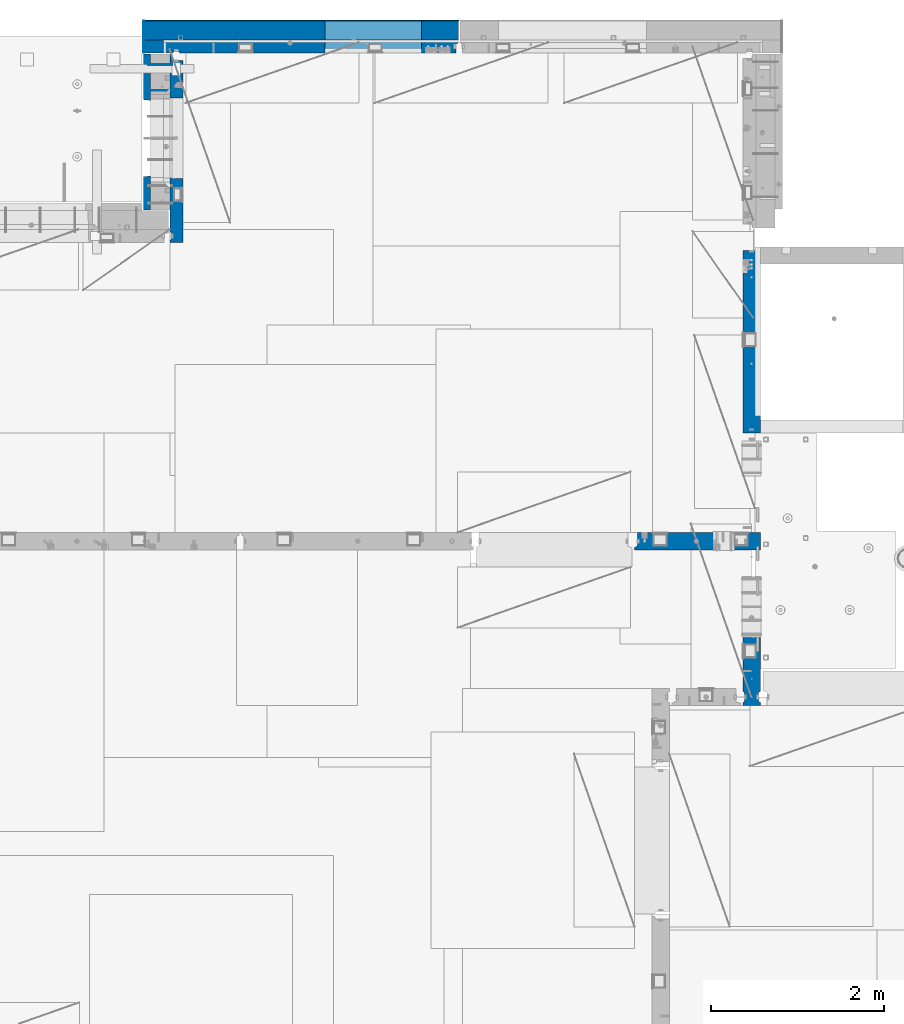
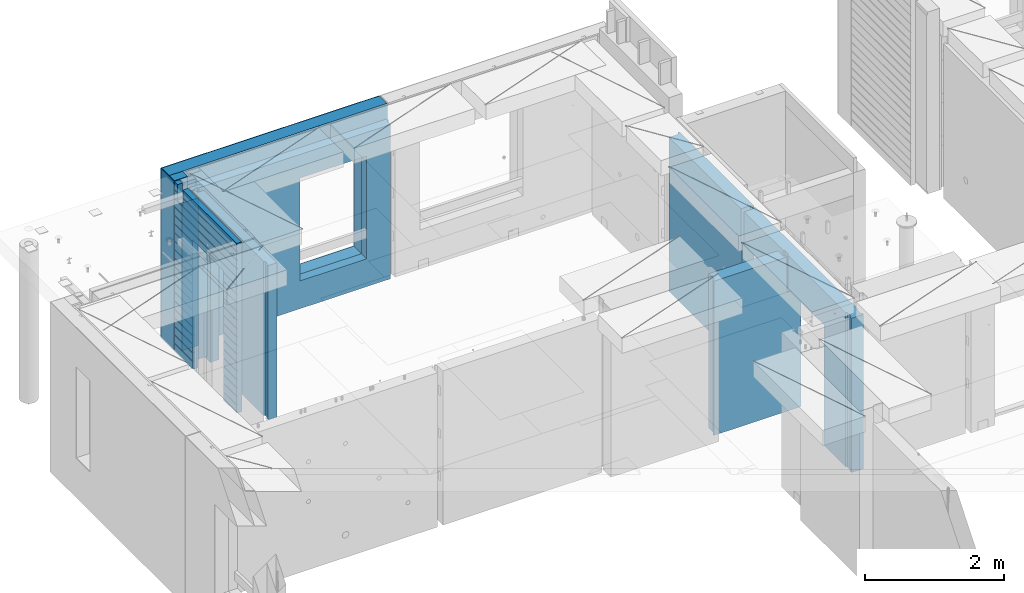
# One storey, part 202 of 309: 12 walls, 5 elements without a shape of their own.
"""IFC2X3 building model written with IfcOpenShell, lengths in millimetres."""

from ifc_helpers import new_model, si_unit, frame, origin_with_axes, place, context, subcontext, project, spatial, faceted_brep, material, type_object, element, aggregate, save


model = new_model("IFC2X3")

# Units and contexts
model_context = context("Model", 3, precision=1e-05, world=origin_with_axes())
body_context = subcontext(model_context, "Body", "Model", "MODEL_VIEW")
ifc_project = project(units=[si_unit("LENGTHUNIT", "METRE", prefix="MILLI"), si_unit("AREAUNIT", "SQUARE_METRE"), si_unit("VOLUMEUNIT", "CUBIC_METRE"), si_unit("MASSUNIT", "GRAM", prefix="KILO"), si_unit("TIMEUNIT", "SECOND"), si_unit("PLANEANGLEUNIT", "RADIAN"), si_unit("SOLIDANGLEUNIT", "STERADIAN"), si_unit("THERMODYNAMICTEMPERATUREUNIT", "DEGREE_CELSIUS"), si_unit("LUMINOUSINTENSITYUNIT", "LUMEN")], contexts=[model_context])

# Site, building, storey
site_placement = place(None, origin_with_axes())
site = spatial("IfcSite", under=ifc_project, at=site_placement, CompositionType="ELEMENT")
building_placement = place(site_placement, origin_with_axes())
building = spatial("IfcBuilding", under=site, at=building_placement, CompositionType="ELEMENT")
storey_placement = place(building_placement, origin_with_axes())
storey = spatial("IfcBuildingStorey", under=building, at=storey_placement, Name="7", CompositionType="ELEMENT", Elevation=0.0)

# Assembly, walls
assembly_1_placement = place(storey_placement, origin_with_axes())
assembly_1 = element("IfcElementAssembly", 1, at=assembly_1_placement, inside=storey, AssemblyPlace="NOTDEFINED", PredefinedType="REINFORCEMENT_UNIT")
ifc_material_1 = material(Name="Undefined")
wall_type_1 = type_object("IfcWallType", PredefinedType="NOTDEFINED")
wall_1_placement = place(assembly_1_placement, frame((11020.0, 22485.0002441406, 101115.0), z_axis=(0.0, 0.0, 1.0), x_axis=(-1.0, 3.00000001838171e-08, 0.0)))
wall_1 = element("IfcWall", 2, at=wall_1_placement, type_object=wall_type_1, material=ifc_material_1, Name="(PD)", context=body_context, shape_type="Brep", body=[
    faceted_brep([(0.0, 5.0, -1300.0), (0.0, 5.0, 1300.0), (280.0, 5.0, 1300.0), (280.0, 5.0, -1300.0), (0.0, -5.0, 1300.0), (280.0, -5.0, 1300.0), (0.0, -5.0, -1300.0), (280.0, -5.0, -1300.0)], [[[0, 1, 2, 3]], [[1, 4, 5, 2]], [[4, 6, 7, 5]], [[6, 0, 3, 7]], [[5, 7, 3, 2]], [[6, 4, 1, 0]]]),
])
wall_2_placement = place(assembly_1_placement, frame((11020.0, 22185.0002441406, 101115.0), z_axis=(0.0, 0.0, 1.0), x_axis=(-1.0, 3.00000001838171e-08, 0.0)))
wall_2 = element("IfcWall", 3, at=wall_2_placement, type_object=wall_type_1, material=ifc_material_1, Name="(PD)", context=body_context, shape_type="Brep", body=[
    faceted_brep([(0.0, 5.0, -1300.0), (0.0, 5.0, 1300.0), (280.0, 5.0, 1300.0), (280.0, 5.0, -1300.0), (0.0, -5.0, 1300.0), (280.0, -5.0, 1300.0), (0.0, -5.0, -1300.0), (280.0, -5.0, -1300.0)], [[[0, 1, 2, 3]], [[1, 4, 5, 2]], [[4, 6, 7, 5]], [[6, 0, 3, 7]], [[5, 7, 3, 2]], [[6, 4, 1, 0]]]),
])

# Assembly, wall
assembly_2_placement = place(storey_placement, origin_with_axes())
assembly_2 = element("IfcElementAssembly", 4, at=assembly_2_placement, inside=storey, AssemblyPlace="NOTDEFINED", PredefinedType="REINFORCEMENT_UNIT")
ifc_material_2 = material(Name="CONCRETE/C25/30")
wall_type_2 = type_object("IfcWallType", PredefinedType="NOTDEFINED")
wall_3_placement = place(assembly_2_placement, frame((17710.0, 18214.9992663657, 101112.5), z_axis=(0.0, 0.0, 1.0), x_axis=(0.0, 1.0, 0.0)))
wall_3 = element("IfcWall", 5, at=wall_3_placement, type_object=wall_type_2, material=ifc_material_2, context=body_context, shape_type="Brep", body=[
    faceted_brep([(2120.00073363433, -57.0000000000036, 1357.5), (2120.00073363433, -57.0000000000036, -1357.5), (2120.00073363433, 100.0, -1357.5), (2120.00073363433, 100.0, 1357.5), (2165.00073363433, -70.0000000000036, 1357.5), (2165.00073363433, -70.0000000000036, -1357.5), (45.0, 100.0, 1357.5), (45.0, 100.0, 762.5), (45.0, -57.0, 762.5), (45.0, -57.0, 1357.5), (15.0, -70.0, 762.5), (15.0, 100.0, 762.5), (15.0, -70.0, 1357.5), (15.0, 100.0, -1357.5), (15.0, -100.0, -1357.5), (15.0, -100.0, 1357.5), (2165.00073363433, -100.0, -1357.5), (2165.00073363433, -100.0, 1357.5)], [[[0, 1, 2, 3]], [[4, 5, 1, 0]], [[6, 7, 8, 9]], [[10, 8, 7, 11]], [[12, 9, 8, 10]], [[11, 13, 14, 15, 12, 10]], [[15, 14, 16, 17]], [[3, 6, 9, 12, 15, 17, 4, 0]], [[13, 11, 7, 6, 3, 2]], [[16, 14, 13, 2, 1, 5]], [[17, 16, 5, 4]]]),
])
aggregate(assembly_2, [wall_3])

assembly_3_placement = place(storey_placement, origin_with_axes())
assembly_3 = element("IfcElementAssembly", 6, at=assembly_3_placement, inside=storey, AssemblyPlace="NOTDEFINED", PredefinedType="REINFORCEMENT_UNIT")
wall_4_placement = place(assembly_3_placement, frame((17710.0, 15080.0, 101112.5), z_axis=(0.0, 0.0, 1.0), x_axis=(0.0, 1.0, 0.0)))
wall_4 = element("IfcWall", 7, at=wall_4_placement, type_object=wall_type_2, material=ifc_material_2, context=body_context, shape_type="Brep", body=[
    faceted_brep([(3089.99926636568, -57.0, 1357.5), (3089.99926636568, -57.0, 762.5), (3089.99926620436, 100.0, 762.5), (3089.99926636568, 100.0, 1357.5), (3119.99926636568, -70.0, 1357.5), (3119.99926636568, -69.9999995451544, 762.5), (1965.00000368528, 100.0, 1357.5), (1965.00000368528, 99.9999997455598, 762.5), (1951.9999991369, 80.0000000823711, 762.5), (1951.9999991369, 80.0000000823711, 1357.5), (1848.00000041054, 79.9999993903439, 762.5), (1848.00000041054, 79.9999993903439, 1357.5), (1835.0, 100.0, 762.5), (1835.0, 100.0, 1357.5), (790.003238525391, -100.0, -1357.5), (790.003238525391, 100.0, -1357.5), (790.003238525391, 100.0, 762.5), (790.003238525391, -100.0, 762.5), (164.999999999998, 100.0, -1357.5), (164.999999999996, 100.0, 1357.5), (47.9997742438973, -79.9991481948964, 1357.5), (47.9997742438991, -79.9991481948928, -1357.5), (152.000000457021, -79.9991466091124, -1357.5), (152.000000457019, -79.9991466091124, 1357.5), (34.9997701872417, -100.0, 1357.5), (34.9997701872435, -100.0, -1357.5), (0.0, -100.0, 1357.5), (0.0, -100.0, -1357.5), (0.0, 100.0, 1357.5), (0.0, 100.0, -1357.5), (35.0, 100.0, 1357.5), (35.0, 100.0, -1357.5), (48.0, 80.0, 1357.5), (48.0, 80.0, -1357.5), (152.0, 80.0, 1357.5), (152.0, 80.0, -1357.5), (165.0, -100.0, -1357.5), (164.999999999998, -99.9991455078125, 1357.5), (3119.99926636568, -100.0, 762.5), (3119.99926636568, -100.0, 1357.5)], [[[0, 1, 2, 3]], [[4, 5, 1, 0]], [[6, 7, 8, 9]], [[9, 8, 10, 11]], [[11, 10, 12, 13]], [[14, 15, 16, 17]], [[13, 12, 16, 15, 18, 19]], [[20, 21, 22, 23]], [[24, 25, 21, 20]], [[26, 27, 25, 24]], [[27, 26, 28, 29]], [[29, 28, 30, 31]], [[32, 33, 31, 30]], [[34, 35, 33, 32]], [[19, 18, 35, 34]], [[15, 14, 36, 22, 21, 25, 27, 29, 31, 33, 35, 18]], [[37, 23, 22, 36]], [[14, 17, 38, 39, 37, 36]], [[13, 19, 34, 32, 30, 28, 26, 24, 20, 23, 37, 39, 4, 0, 3, 6, 9, 11]], [[7, 6, 3, 2]], [[38, 17, 16, 12, 10, 8, 7, 2, 1, 5]], [[39, 38, 5, 4]]]),
])
aggregate(assembly_3, [wall_4])

assembly_4_placement = place(storey_placement, origin_with_axes())
assembly_4 = element("IfcElementAssembly", 8, at=assembly_4_placement, inside=storey, AssemblyPlace="NOTDEFINED", PredefinedType="REINFORCEMENT_UNIT")
wall_5_placement = place(assembly_4_placement, frame((16359.9991042544, 16980.0, 101112.5), z_axis=(0.0, 0.0, 1.0), x_axis=(1.0, 0.0, 0.0)))
wall_5 = element("IfcWall", 9, at=wall_5_placement, type_object=wall_type_2, material=ifc_material_2, context=body_context, shape_type="Brep", body=[
    faceted_brep([(1185.00089736511, 100.0, 1357.5), (1185.00089574558, -57.0, 1357.5), (1185.00089574558, -57.0, 742.5), (1185.00089736511, 99.9999999278843, 742.5), (1220.00089574558, -72.1666661360759, 1357.5), (1220.00089574558, -72.1666661360759, 742.5), (1220.00089574558, 100.000001967095, 742.5), (1220.00089574558, -100.0, 1357.5), (0.0, -100.0, 1357.5), (0.0, -100.0, -1357.5), (1450.0, -100.0, -1357.5), (1450.0, -100.0, 742.5), (1220.00089574558, -100.0, 742.5), (0.0, -70.0000178764712, 1357.5), (0.0, -70.0000178764712, -1357.5), (30.0000412533973, -57.0, 1357.5), (30.0000412533973, -57.0, -1357.5), (30.0000000000009, 100.0, 1357.5), (30.0, 100.0, -1357.5), (1450.0, 100.0, -1357.5), (1450.00089574558, 100.0, 742.5)], [[[0, 1, 2, 3]], [[4, 5, 2, 1]], [[6, 3, 2, 5]], [[7, 8, 9, 10, 11, 12]], [[9, 8, 13, 14]], [[15, 16, 14, 13]], [[17, 18, 16, 15]], [[19, 10, 9, 14, 16, 18]], [[10, 19, 20, 11]], [[12, 11, 20, 6, 5]], [[7, 12, 5, 4]], [[0, 17, 15, 13, 8, 7, 4, 1]], [[20, 19, 18, 17, 0, 3, 6]]]),
])
aggregate(assembly_4, [wall_5])

# Assembly, walls
assembly_5_placement = place(storey_placement, origin_with_axes())
assembly_5 = element("IfcElementAssembly", 10, at=assembly_5_placement, inside=storey, AssemblyPlace="NOTDEFINED", PredefinedType="REINFORCEMENT_UNIT")
ifc_material_3 = material()
wall_type_3 = type_object("IfcWallType", PredefinedType="NOTDEFINED")
wall_6_placement = place(assembly_5_placement, frame((10805.0, 22620.0, 101247.5), z_axis=(0.0, 0.0, 1.0), x_axis=(0.0, 1.0, 0.0)))
wall_6 = element("IfcWall", 11, at=wall_6_placement, type_object=wall_type_3, material=ifc_material_3, context=body_context, shape_type="Brep", body=[
    faceted_brep([(0.0, 110.0, -1492.5), (0.0, 110.0, 1492.5), (150.0, 110.0, 1492.5), (150.0, 110.0, -1492.5), (0.0, -110.0, 1492.5), (150.0, -110.0, 1492.5), (0.0, -110.0, -1492.5), (150.0, -110.0, -1492.5)], [[[0, 1, 2, 3]], [[1, 4, 5, 2]], [[4, 6, 7, 5]], [[6, 0, 3, 7]], [[5, 7, 3, 2]], [[6, 4, 1, 0]]]),
])
wall_7_placement = place(assembly_5_placement, frame((10915.0, 22880.0, 101247.5), z_axis=(0.0, 0.0, 1.0), x_axis=(1.0, 0.0, 0.0)))
wall_7 = element("IfcWall", 12, at=wall_7_placement, type_object=wall_type_3, material=ifc_material_3, context=body_context, shape_type="Brep", body=[
    faceted_brep([(-220.0, -110.0, -1492.5), (-220.0, 110.0, -1492.5), (3410.0, 110.0, -1492.5), (3410.0, -110.0, -1492.5), (-220.0, -110.0, 1492.5), (-220.0, 110.0, 1492.5), (3410.0, -110.0, 1492.5), (3410.0, 110.0, 1492.5), (1869.99971073172, 110.0, -1002.5), (2979.99971073172, 110.0, -1002.5), (2979.99971073172, 110.0, 807.5), (1869.99971073172, 110.0, 807.5), (1869.99971073172, -110.0, -1002.5), (1869.99971073172, -110.0, 807.5), (2979.99971073172, -110.0, 807.5), (2979.99971073172, -110.0, -1002.5)], [[[0, 1, 2, 3]], [[0, 4, 5, 1]], [[5, 4, 6, 7]], [[1, 5, 7, 2], [8, 9, 10, 11]], [[6, 3, 2, 7]], [[4, 0, 3, 6], [12, 13, 14, 15]], [[10, 14, 13, 11]], [[9, 15, 14, 10]], [[8, 12, 15, 9]], [[11, 13, 12, 8]]]),
])

# Wall
ifc_material_4 = material(Name="CONCRETE/C30/37")
wall_type_4 = type_object("IfcWallType", PredefinedType="NOTDEFINED")
wall_8_placement = place(assembly_1_placement, frame((10727.5, 20805.0, 101247.5), z_axis=(0.0, 0.0, 1.0), x_axis=(0.0, 1.0, 0.0)))
wall_8 = element("IfcWall", 13, at=wall_8_placement, type_object=wall_type_4, material=ifc_material_4, context=body_context, shape_type="Brep", body=[
    faceted_brep([(1800.0, -42.5, 1492.5), (1800.0, 42.5, 1492.5), (1705.0, 42.5, 1492.5), (1705.0, -42.5, 1492.5), (0.0, 42.5, -1492.5), (0.0, 42.5, -1357.00000005524), (384.998212827581, 42.5, -1357.00000005524), (384.998212827581, 42.5, -1492.5), (0.0, 32.4999992507037, -1355.00000000074), (386.174879582417, 32.4999992506928, -1355.0000000008), (0.0, 32.4999991127006, -1344.99999959956), (386.174879598653, 32.4999991126915, -1344.99999959957), (0.0, 42.5, -1343.00000011075), (384.998212827581, 42.5, -1343.00000011075), (0.0, 42.5, -1207.00000005524), (384.998212827581, 42.5, -1207.00000005524), (0.0, 32.4999992507037, -1205.00000000074), (386.174879582417, 32.4999992506928, -1205.0000000008), (0.0, 32.4999991127006, -1194.99999959956), (386.174879598653, 32.4999991126915, -1194.99999959957), (0.0, 42.5, -1193.00000011075), (384.998212827581, 42.5, -1193.00000011075), (0.0, 42.5, -1057.00000005524), (384.998212827581, 42.5, -1057.00000005524), (0.0, 32.4999992507037, -1055.00000000074), (386.174879582417, 32.4999992506928, -1055.0000000008), (0.0, 32.4999991127006, -1044.99999959956), (386.174879598653, 32.4999991126915, -1044.99999959957), (0.0, 42.5, -1043.00000011075), (384.998212827581, 42.5, -1043.00000011075), (0.0, 42.5, -907.000000055239), (384.998212827581, 42.5, -907.000000055239), (0.0, 32.4999992507037, -905.000000000742), (386.174879582417, 32.4999992506928, -905.0000000008), (0.0, 32.4999991127006, -894.99999959956), (386.174879598653, 32.4999991126915, -894.999999599575), (0.0, 42.5, -893.000000110755), (384.998212827581, 42.5, -893.000000110755), (0.0, 42.5, -757.000000055239), (384.998212827581, 42.5, -757.000000055239), (0.0, 32.4999992507037, -755.000000000742), (386.174879582417, 32.4999992506928, -755.0000000008), (0.0, 32.4999991127006, -744.99999959956), (386.174879598653, 32.4999991126915, -744.999999599575), (0.0, 42.5, -743.000000110755), (384.998212827581, 42.5, -743.000000110755), (0.0, 42.5, -607.000000055239), (384.998212827581, 42.5, -607.000000055239), (3.63797880709171e-12, 32.4999992507037, -605.000000000742), (386.174879582417, 32.4999992506928, -605.0000000008), (3.63797880709171e-12, 32.4999991127006, -594.99999959956), (386.174879598653, 32.4999991126915, -594.999999599575), (0.0, 42.5, -593.000000110755), (384.998212827581, 42.5, -593.000000110755), (0.0, 42.5, -457.000000055239), (384.998212827581, 42.5, -457.000000055239), (0.0, 32.4999992507037, -455.000000000742), (386.174879582417, 32.4999992506928, -455.0000000008), (0.0, 32.4999991127006, -444.99999959956), (386.174879598653, 32.4999991126915, -444.999999599575), (0.0, 42.5, -443.000000110755), (384.998212827581, 42.5, -443.000000110755), (0.0, 42.5, -307.000000055239), (384.998212827581, 42.5, -307.000000055239), (0.0, 32.4999992507037, -305.000000000742), (386.174879582417, 32.4999992506928, -305.0000000008), (0.0, 32.4999991127006, -294.99999959956), (386.174879598653, 32.4999991126915, -294.999999599575), (0.0, 42.5, -293.000000110755), (384.998212827581, 42.5, -293.000000110755), (0.0, 42.5, -157.000000055239), (384.998212827581, 42.5, -157.000000055239), (3.63797880709171e-12, 32.4999992507037, -155.000000000742), (386.174879582417, 32.4999992506928, -155.0000000008), (3.63797880709171e-12, 32.4999991127006, -144.99999959956), (386.174879598653, 32.4999991126915, -144.999999599575), (0.0, 42.5, -143.000000110755), (384.998212827581, 42.5, -143.000000110755), (0.0, 42.5, -7.00000005523907), (384.998212827581, 42.5, -7.00000005523907), (0.0, 32.4999992507037, -5.00000000074215), (386.174879582417, 32.4999992506928, -5.00000000080036), (0.0, 32.4999991127006, 5.0000004004396), (386.174879598653, 32.4999991126915, 5.00000040042505), (0.0, 42.5, 6.99999988924537), (384.998212827581, 42.5, 6.99999988924537), (0.0, 42.5, 142.999999944761), (384.998212827581, 42.5, 142.999999944761), (-3.63797880709171e-12, 32.4999992507037, 144.999999999258), (386.174879582417, 32.4999992506928, 144.9999999992), (-3.63797880709171e-12, 32.4999991127006, 155.00000040044), (386.174879598653, 32.4999991126915, 155.000000400425), (0.0, 42.5, 156.999999889245), (384.998212827581, 42.5, 156.999999889245), (0.0, 42.5, 292.999999944761), (384.998212827581, 42.5, 292.999999944761), (-3.63797880709171e-12, 32.4999992507037, 294.999999999258), (386.174879582417, 32.4999992506928, 294.9999999992), (-3.63797880709171e-12, 32.4999991127006, 305.00000040044), (386.174879598653, 32.4999991126915, 305.000000400425), (0.0, 42.5, 306.999999889245), (384.998212827581, 42.5, 306.999999889245), (0.0, 42.5, 442.999999944761), (384.998212827581, 42.5, 442.999999944761), (0.0, 32.4999992507037, 444.999999999258), (386.174879582417, 32.4999992506928, 444.9999999992), (0.0, 32.4999991127006, 455.00000040044), (386.174879598653, 32.4999991126915, 455.000000400425), (0.0, 42.5, 456.999999889245), (384.998212827581, 42.5, 456.999999889245), (0.0, 42.5, 592.999999944761), (384.998212827581, 42.5, 592.999999944761), (3.63797880709171e-12, 32.4999992507037, 594.999999999258), (386.174879582417, 32.4999992506928, 594.9999999992), (3.63797880709171e-12, 32.4999991127006, 605.00000040044), (386.174879598653, 32.4999991126915, 605.000000400425), (0.0, 42.5, 606.999999889245), (384.998212827581, 42.5, 606.999999889245), (0.0, 42.5, 742.999999944761), (384.998212827581, 42.5, 742.999999944761), (0.0, 32.4999992507037, 744.999999999258), (386.174879582417, 32.4999992506928, 744.9999999992), (0.0, 32.4999991127006, 755.00000040044), (386.174879598653, 32.4999991126915, 755.000000400425), (0.0, 42.5, 756.999999889245), (384.998212827581, 42.5, 756.999999889245), (0.0, 42.5, 1206.99999988925), (1800.0, 42.5, 1206.99999988925), (1800.0, 32.4999991126897, 1205.00000040043), (0.0, 32.4999991127006, 1205.00000040044), (1800.0, 32.4999992507001, 1194.99999999923), (0.0, 32.4999992507037, 1194.99999999926), (0.0, 42.5, 1192.99999994476), (1800.0, 42.5, 1192.99999994476), (1800.0, 42.5, 1056.99999988925), (0.0, 42.5, 1056.99999988925), (1800.0, 32.4999991126897, 1055.00000040043), (0.0, 32.4999991127006, 1055.00000040044), (1800.0, 32.4999992507001, 1044.99999999923), (0.0, 32.4999992507037, 1044.99999999926), (0.0, 42.5, 1042.99999994476), (1800.0, 42.5, 1042.99999994476), (1800.0, 42.5, 906.999999889245), (0.0, 42.5, 906.999999889245), (1800.0, 32.4999991126897, 905.000000400425), (0.0, 32.4999991127006, 905.00000040044), (1800.0, 32.4999992507001, 894.999999999229), (0.0, 32.4999992507037, 894.999999999258), (0.0, 42.5, 892.999999944761), (1800.0, 42.5, 892.999999944761), (1800.0, 42.5, -1357.00000005524), (1800.0, 42.5, -1492.5), (1274.99821282758, 42.5, -1492.5), (1274.99821282758, 42.5, -1357.00000005524), (1800.0, 32.4999992507001, -1355.00000000077), (1273.82154607274, 32.4999992506928, -1355.0000000008), (1800.0, 32.4999991126897, -1344.99999959957), (1273.82154605651, 32.4999991126915, -1344.99999959957), (1800.0, 42.5, -1343.00000011075), (1274.99821282758, 42.5, -1343.00000011075), (1800.0, 42.5, -1207.00000005524), (1274.99821282758, 42.5, -1207.00000005524), (1800.0, 32.4999992507001, -1205.00000000077), (1273.82154607274, 32.4999992506928, -1205.0000000008), (1800.0, 32.4999991126897, -1194.99999959957), (1273.82154605651, 32.4999991126915, -1194.99999959957), (1800.0, 42.5, -1193.00000011075), (1274.99821282758, 42.5, -1193.00000011075), (1800.0, 42.5, -1057.00000005524), (1274.99821282758, 42.5, -1057.00000005524), (1800.0, 32.4999992507001, -1055.00000000077), (1273.82154607274, 32.4999992506928, -1055.0000000008), (1800.0, 32.4999991126897, -1044.99999959957), (1273.82154605651, 32.4999991126915, -1044.99999959957), (1800.0, 42.5, -1043.00000011075), (1274.99821282758, 42.5, -1043.00000011075), (1800.0, 42.5, -907.000000055239), (1274.99821282758, 42.5, -907.000000055239), (1800.0, 32.4999992507001, -905.000000000771), (1273.82154607274, 32.4999992506928, -905.0000000008), (1800.0, 32.4999991126897, -894.999999599575), (1273.82154605651, 32.4999991126915, -894.999999599575), (1800.0, 42.5, -893.000000110755), (1274.99821282758, 42.5, -893.000000110755), (1800.0, 42.5, -757.000000055239), (1274.99821282758, 42.5, -757.000000055239), (1800.0, 32.4999992507001, -755.000000000771), (1273.82154607274, 32.4999992506928, -755.0000000008), (1800.0, 32.4999991126897, -744.999999599575), (1273.82154605651, 32.4999991126915, -744.999999599575), (1800.0, 42.5, -743.000000110755), (1274.99821282758, 42.5, -743.000000110755), (1800.0, 42.5, -607.000000055239), (1274.99821282758, 42.5, -607.000000055239), (1800.0, 32.4999992507001, -605.000000000771), (1273.82154607274, 32.4999992506928, -605.0000000008), (1800.0, 32.4999991126897, -594.999999599575), (1273.82154605651, 32.4999991126915, -594.999999599575), (1800.0, 42.5, -593.000000110755), (1274.99821282758, 42.5, -593.000000110755), (1800.0, 42.5, -457.000000055239), (1274.99821282758, 42.5, -457.000000055239), (1800.0, 32.4999992507001, -455.000000000771), (1273.82154607274, 32.4999992506928, -455.0000000008), (1800.0, 32.4999991126897, -444.999999599575), (1273.82154605651, 32.4999991126915, -444.999999599575), (1800.0, 42.5, -443.000000110755), (1274.99821282758, 42.5, -443.000000110755), (1800.0, 42.5, -307.000000055239), (1274.99821282758, 42.5, -307.000000055239), (1800.0, 32.4999992507001, -305.000000000771), (1273.82154607274, 32.4999992506928, -305.0000000008), (1800.0, 32.4999991126897, -294.999999599575), (1273.82154605651, 32.4999991126915, -294.999999599575), (1800.0, 42.5, -293.000000110755), (1274.99821282758, 42.5, -293.000000110755), (1800.0, 42.5, -157.000000055239), (1274.99821282758, 42.5, -157.000000055239), (1800.0, 32.4999992507001, -155.000000000771), (1273.82154607274, 32.4999992506928, -155.0000000008), (1800.0, 32.4999991126897, -144.999999599575), (1273.82154605651, 32.4999991126915, -144.999999599575), (1800.0, 42.5, -143.000000110755), (1274.99821282758, 42.5, -143.000000110755), (1800.0, 42.5, -7.00000005523907), (1274.99821282758, 42.5, -7.00000005523907), (1800.0, 32.4999992507001, -5.00000000077125), (1273.82154607274, 32.4999992506928, -5.00000000080036), (1800.0, 32.4999991126897, 5.00000040042505), (1273.82154605651, 32.4999991126915, 5.00000040042505), (1800.0, 42.5, 6.99999988924537), (1274.99821282758, 42.5, 6.99999988924537), (1800.0, 42.5, 142.999999944761), (1274.99821282758, 42.5, 142.999999944761), (1800.0, 32.4999992507001, 144.999999999229), (1273.82154607274, 32.4999992506928, 144.9999999992), (1800.0, 32.4999991126897, 155.000000400425), (1273.82154605651, 32.4999991126915, 155.000000400425), (1800.0, 42.5, 156.999999889245), (1274.99821282758, 42.5, 156.999999889245), (1800.0, 42.5, 292.999999944761), (1274.99821282758, 42.5, 292.999999944761), (1800.0, 32.4999992507001, 294.999999999229), (1273.82154607274, 32.4999992506928, 294.9999999992), (1800.0, 32.4999991126897, 305.000000400425), (1273.82154605651, 32.4999991126915, 305.000000400425), (1800.0, 42.5, 306.999999889245), (1274.99821282758, 42.5, 306.999999889245), (1800.0, 42.5, 442.999999944761), (1274.99821282758, 42.5, 442.999999944761), (1800.0, 32.4999992507001, 444.999999999229), (1273.82154607274, 32.4999992506928, 444.9999999992), (1800.0, 32.4999991126897, 455.000000400425), (1273.82154605651, 32.4999991126915, 455.000000400425), (1800.0, 42.5, 456.999999889245), (1274.99821282758, 42.5, 456.999999889245), (1800.0, 42.5, 592.999999944761), (1274.99821282758, 42.5, 592.999999944761), (1800.0, 32.4999992507001, 594.999999999229), (1273.82154607274, 32.4999992506928, 594.9999999992), (1800.0, 32.4999991126897, 605.000000400425), (1273.82154605651, 32.4999991126915, 605.000000400425), (1800.0, 42.5, 606.999999889245), (1274.99821282758, 42.5, 606.999999889245), (1800.0, 42.5, 742.999999944761), (1274.99821282758, 42.5, 742.999999944761), (1800.0, 32.4999992507001, 744.999999999229), (1273.82154607274, 32.4999992506928, 744.9999999992), (1800.0, 32.4999991126897, 755.000000400425), (1273.82154605651, 32.4999991126915, 755.000000400425), (1800.0, 42.5, 756.999999889245), (1274.99821282758, 42.5, 756.999999889245), (395.000271651108, 42.5, 782.5), (384.998212827581, 42.5, 782.5), (1274.99821282758, 42.5, 782.5), (1265.00027165111, 42.5, 782.5), (394.999879494248, -42.5, 787.502857142856), (1264.99654616091, -42.5, 787.502857142856), (394.999879494248, -42.5, 782.5), (394.999879494248, -42.5, -1492.5), (0.0, -42.5, -1492.5), (-3.63797880709171e-12, 32.4999992507037, 1344.99999999926), (0.0, 42.5, 1342.99999994476), (0.0, -42.5, 1492.5), (0.0, 42.5, 1492.5), (0.0, 42.5, 1356.99999988925), (-3.63797880709171e-12, 32.4999991127006, 1355.00000040044), (1555.0, 42.5, 1356.99999988925), (1555.0, 32.4999991126915, 1355.00000040043), (1555.0, 32.4999992506928, 1344.9999999992), (1555.0, 42.5, 1342.99999994476), (1800.0, 42.5, 1342.99999994476), (1555.0, 42.5, 1222.5), (1705.0, 42.5, 1222.5), (1705.0, 42.5, 1343.0), (1800.0, 32.4999992507001, 1344.99999999923), (1705.0, 32.5, 1345.0), (1800.0, 32.4999991126897, 1355.00000040043), (1705.0, 32.5, 1355.0), (1800.0, 42.5, 1356.99999988925), (1705.0, 42.5, 1357.0), (1800.0, -42.5, -1492.5), (1264.99654616091, -42.5, -1492.5), (1264.99654616091, -42.5, 782.5), (1705.0, -42.5, 1222.5), (1555.0, -42.5, 1222.5), (1555.0, -42.5, 1492.5), (1555.0, 42.5, 1492.5)], [[[0, 1, 2, 3]], [[4, 5, 6, 7]], [[5, 8, 9, 6]], [[8, 10, 11, 9]], [[10, 12, 13, 11]], [[12, 14, 15, 13]], [[14, 16, 17, 15]], [[16, 18, 19, 17]], [[18, 20, 21, 19]], [[20, 22, 23, 21]], [[22, 24, 25, 23]], [[24, 26, 27, 25]], [[26, 28, 29, 27]], [[28, 30, 31, 29]], [[30, 32, 33, 31]], [[32, 34, 35, 33]], [[34, 36, 37, 35]], [[36, 38, 39, 37]], [[38, 40, 41, 39]], [[40, 42, 43, 41]], [[42, 44, 45, 43]], [[44, 46, 47, 45]], [[46, 48, 49, 47]], [[48, 50, 51, 49]], [[50, 52, 53, 51]], [[52, 54, 55, 53]], [[54, 56, 57, 55]], [[56, 58, 59, 57]], [[58, 60, 61, 59]], [[60, 62, 63, 61]], [[62, 64, 65, 63]], [[64, 66, 67, 65]], [[66, 68, 69, 67]], [[68, 70, 71, 69]], [[70, 72, 73, 71]], [[72, 74, 75, 73]], [[74, 76, 77, 75]], [[76, 78, 79, 77]], [[78, 80, 81, 79]], [[80, 82, 83, 81]], [[82, 84, 85, 83]], [[84, 86, 87, 85]], [[86, 88, 89, 87]], [[88, 90, 91, 89]], [[90, 92, 93, 91]], [[92, 94, 95, 93]], [[94, 96, 97, 95]], [[96, 98, 99, 97]], [[98, 100, 101, 99]], [[100, 102, 103, 101]], [[102, 104, 105, 103]], [[104, 106, 107, 105]], [[106, 108, 109, 107]], [[108, 110, 111, 109]], [[110, 112, 113, 111]], [[112, 114, 115, 113]], [[114, 116, 117, 115]], [[116, 118, 119, 117]], [[118, 120, 121, 119]], [[120, 122, 123, 121]], [[122, 124, 125, 123]], [[126, 127, 128, 129]], [[129, 128, 130, 131]], [[132, 131, 130, 133]], [[134, 135, 132, 133]], [[135, 134, 136, 137]], [[137, 136, 138, 139]], [[140, 139, 138, 141]], [[142, 143, 140, 141]], [[143, 142, 144, 145]], [[145, 144, 146, 147]], [[148, 147, 146, 149]], [[150, 151, 152, 153]], [[154, 150, 153, 155]], [[156, 154, 155, 157]], [[158, 156, 157, 159]], [[160, 158, 159, 161]], [[162, 160, 161, 163]], [[164, 162, 163, 165]], [[166, 164, 165, 167]], [[168, 166, 167, 169]], [[170, 168, 169, 171]], [[172, 170, 171, 173]], [[174, 172, 173, 175]], [[176, 174, 175, 177]], [[178, 176, 177, 179]], [[180, 178, 179, 181]], [[182, 180, 181, 183]], [[184, 182, 183, 185]], [[186, 184, 185, 187]], [[188, 186, 187, 189]], [[190, 188, 189, 191]], [[192, 190, 191, 193]], [[194, 192, 193, 195]], [[196, 194, 195, 197]], [[198, 196, 197, 199]], [[200, 198, 199, 201]], [[202, 200, 201, 203]], [[204, 202, 203, 205]], [[206, 204, 205, 207]], [[208, 206, 207, 209]], [[210, 208, 209, 211]], [[212, 210, 211, 213]], [[214, 212, 213, 215]], [[216, 214, 215, 217]], [[218, 216, 217, 219]], [[220, 218, 219, 221]], [[222, 220, 221, 223]], [[224, 222, 223, 225]], [[226, 224, 225, 227]], [[228, 226, 227, 229]], [[230, 228, 229, 231]], [[232, 230, 231, 233]], [[234, 232, 233, 235]], [[236, 234, 235, 237]], [[238, 236, 237, 239]], [[240, 238, 239, 241]], [[242, 240, 241, 243]], [[244, 242, 243, 245]], [[246, 244, 245, 247]], [[248, 246, 247, 249]], [[250, 248, 249, 251]], [[252, 250, 251, 253]], [[254, 252, 253, 255]], [[256, 254, 255, 257]], [[258, 256, 257, 259]], [[260, 258, 259, 261]], [[262, 260, 261, 263]], [[264, 262, 263, 265]], [[266, 264, 265, 267]], [[268, 266, 267, 269]], [[270, 268, 269, 271]], [[272, 273, 125, 124, 148, 149, 270, 271, 274, 275]], [[276, 273, 272, 275, 274, 277]], [[278, 279, 7, 6, 9, 11, 13, 15, 17, 19, 21, 23, 25, 27, 29, 31, 33, 35, 37, 39, 41, 43, 45, 47, 49, 51, 53, 55, 57, 59, 61, 63, 65, 67, 69, 71, 73, 75, 77, 79, 81, 83, 85, 87, 89, 91, 93, 95, 97, 99, 101, 103, 105, 107, 109, 111, 113, 115, 117, 119, 121, 123, 125, 273, 276]], [[280, 4, 7, 279]], [[281, 282, 126, 129, 131, 132, 135, 137, 139, 140, 143, 145, 147, 148, 124, 122, 120, 118, 116, 114, 112, 110, 108, 106, 104, 102, 100, 98, 96, 94, 92, 90, 88, 86, 84, 82, 80, 78, 76, 74, 72, 70, 68, 66, 64, 62, 60, 58, 56, 54, 52, 50, 48, 46, 44, 42, 40, 38, 36, 34, 32, 30, 28, 26, 24, 22, 20, 18, 16, 14, 12, 10, 8, 5, 4, 280, 283, 284, 285, 286]], [[286, 285, 287, 288]], [[281, 286, 288, 289]], [[282, 281, 289, 290]], [[291, 127, 126, 282, 290, 292, 293, 294]], [[295, 291, 294, 296]], [[297, 295, 296, 298]], [[299, 297, 298, 300]], [[1, 0, 301, 151, 150, 154, 156, 158, 160, 162, 164, 166, 168, 170, 172, 174, 176, 178, 180, 182, 184, 186, 188, 190, 192, 194, 196, 198, 200, 202, 204, 206, 208, 210, 212, 214, 216, 218, 220, 222, 224, 226, 228, 230, 232, 234, 236, 238, 240, 242, 244, 246, 248, 250, 252, 254, 256, 258, 260, 262, 264, 266, 268, 270, 149, 146, 144, 142, 141, 138, 136, 134, 133, 130, 128, 127, 291, 295, 297, 299]], [[151, 301, 302, 152]], [[303, 277, 274, 271, 269, 267, 265, 263, 261, 259, 257, 255, 253, 251, 249, 247, 245, 243, 241, 239, 237, 235, 233, 231, 229, 227, 225, 223, 221, 219, 217, 215, 213, 211, 209, 207, 205, 203, 201, 199, 197, 195, 193, 191, 189, 187, 185, 183, 181, 179, 177, 175, 173, 171, 169, 167, 165, 163, 161, 159, 157, 155, 153, 152, 302]], [[302, 301, 0, 3, 304, 305, 306, 283, 280, 279, 278, 276, 277, 303]], [[284, 283, 306, 307]], [[285, 284, 307, 287]], [[306, 305, 292, 290, 289, 288, 287, 307]], [[304, 293, 292, 305]], [[3, 2, 300, 298, 296, 294, 293, 304]], [[1, 299, 300, 2]]]),
])

wall_type_5 = type_object("IfcWallType", PredefinedType="NOTDEFINED")
wall_9_placement = place(assembly_1_placement, frame((11065.0, 20430.0, 101112.5), z_axis=(0.0, 0.0, 1.0), x_axis=(0.0, 1.0, 0.0)))
wall_9 = element("IfcWall", 14, at=wall_9_placement, type_object=wall_type_5, material=ifc_material_2, context=body_context, shape_type="Brep", body=[
    faceted_brep([(124.995187227563, 75.0, 1357.5), (124.995187227563, 75.0, -1357.5), (114.995187227563, 55.0, -1357.5), (114.995187227563, 55.0, 1357.5), (-0.00481277243670775, -75.0, -1357.5), (-0.00481277243670775, -75.0, 1357.5), (-0.00481277243670775, 75.0, 1357.5), (-0.00481277243670775, 75.0, -1357.5), (24.9951872275633, 75.0, 1357.5), (24.9951872275633, 75.0, -1357.5), (34.9951872275633, 55.0, 1357.5), (34.9951872275633, 55.0, -1357.5), (47.9951869124525, 54.9999994175378, 1357.5), (47.9951869124525, 54.9999994175378, -1357.5), (101.995186816988, 54.9999993903693, 1357.5), (101.995186816988, 54.9999993903693, -1357.5), (2105.0, -75.0, 1357.5), (2105.0, 32.0, 1357.5), (2175.0, 45.0, 1357.5), (2175.0, 75.0, 1357.5), (2105.0, -75.0, -1357.5), (2105.0, 32.0, -1357.5), (2175.0, 45.0, -1357.5), (2175.0, 75.0, -1357.5), (743.846425497264, 75.0, -1357.5), (1666.15411780495, 75.0, -1357.5), (1666.15411780496, 75.0, 948.653846153844), (743.846425497261, 75.0, 948.653846153844), (740.000271651108, -75.0, -1357.5), (740.000271651108, -75.0, 952.5), (1670.00027165111, -75.0, 952.5), (1670.00027165111, -75.0, -1357.5)], [[[0, 1, 2, 3]], [[4, 5, 6, 7]], [[7, 6, 8, 9]], [[10, 11, 9, 8]], [[12, 13, 11, 10]], [[14, 15, 13, 12]], [[3, 2, 15, 14]], [[12, 10, 8, 6, 5, 16, 17, 18, 19, 0, 3, 14]], [[16, 20, 21, 17]], [[17, 21, 22, 18]], [[23, 19, 18, 22]], [[24, 1, 0, 19, 23, 25, 26, 27]], [[4, 7, 9, 11, 13, 15, 2, 1, 24, 28]], [[20, 16, 5, 4, 28, 29, 30, 31]], [[23, 22, 21, 20, 31, 25]], [[30, 26, 25, 31]], [[29, 27, 26, 30]], [[28, 24, 27, 29]]]),
])

aggregate(assembly_1, [wall_1, wall_2, wall_8, wall_9])

wall_10_placement = place(assembly_5_placement, frame((11142.5, 22695.0, 101112.5), z_axis=(0.0, 0.0, 1.0), x_axis=(1.0, 0.0, 0.0)))
wall_10 = element("IfcWall", 15, at=wall_10_placement, type_object=wall_type_5, material=ifc_material_2, context=body_context, shape_type="Brep", body=[
    faceted_brep([(1642.49971073172, 75.0, 942.5), (1642.49971073172, -75.0000009442883, 942.5), (1642.49971073172, -75.0000001775006, -867.5), (1642.49971073172, 75.0, -867.5), (2752.49971073172, -74.999999784668, -867.5), (2752.49971073172, 75.0, -867.5), (2752.49971073172, -75.0000005514557, 942.5), (2752.49971073172, 75.0, 942.5), (-227.5, 75.0, -1357.5), (-227.5, 75.0, 1357.5), (3182.5, 75.0, 1357.5), (3182.5, 75.0, -1357.5), (-227.5, -75.0, -1357.5), (-227.5, -75.0, 1357.5), (-117.5, -75.0, -1357.5), (-117.5, -75.0, 1357.5), (-104.499999589396, -54.9999993903875, -1357.5), (-104.499999589396, -54.9999993903875, 1357.5), (-50.4999996848892, -54.9999994175341, -1357.5), (-50.4999996848892, -54.9999994175341, 1357.5), (-37.4999972154728, -75.0000022791319, 1357.5), (-37.4999972154728, -75.0, -1357.5), (3152.5, -75.0000000212349, 1357.5), (3152.5, 24.9999980926514, 1357.5), (3182.5, 45.0, 1357.5), (3182.5, 45.0, -1357.5), (3152.5, -75.0, -1357.5), (3152.5, 24.9999980926514, -1357.5)], [[[0, 1, 2, 3]], [[3, 2, 4, 5]], [[5, 4, 6, 7]], [[7, 6, 1, 0]], [[8, 9, 10, 11], [3, 5, 7, 0]], [[12, 13, 9, 8]], [[13, 12, 14, 15]], [[15, 14, 16, 17]], [[17, 16, 18, 19]], [[20, 19, 18, 21]], [[10, 9, 13, 15, 17, 19, 20, 22, 23, 24]], [[11, 10, 24, 25]], [[26, 21, 18, 16, 14, 12, 8, 11, 25, 27]], [[24, 23, 27, 25]], [[22, 26, 27, 23]], [[20, 21, 26, 22], [2, 1, 6, 4]]]),
])

wall_type_6 = type_object("IfcWallType", PredefinedType="NOTDEFINED")
wall_11_placement = place(assembly_5_placement, frame((10690.0, 22620.0, 101247.5), z_axis=(0.0, 0.0, 1.0), x_axis=(0.0, 1.0, 0.0)))
wall_11 = element("IfcWall", 16, at=wall_11_placement, type_object=wall_type_6, material=ifc_material_4, context=body_context, shape_type="Brep", body=[
    faceted_brep([(0.0, 5.0, -1492.5), (0.0, 5.0, 1492.5), (370.0, 5.0, 1492.5), (370.0, 5.0, -1492.5), (0.0, -5.0, 1492.5), (370.0, -5.0, 1492.5), (0.0, -5.0, -1492.5), (370.0, -5.0, -1492.5)], [[[0, 1, 2, 3]], [[1, 4, 5, 2]], [[4, 6, 7, 5]], [[6, 0, 3, 7]], [[5, 7, 3, 2]], [[6, 4, 1, 0]]]),
])

wall_12_placement = place(assembly_5_placement, frame((10915.0, 22995.0, 101247.5), z_axis=(0.0, 0.0, 1.0), x_axis=(1.0, 0.0, 0.0)))
wall_12 = element("IfcWall", 17, at=wall_12_placement, type_object=wall_type_6, material=ifc_material_4, context=body_context, shape_type="Brep", body=[
    faceted_brep([(-230.0, -5.0, -1492.5), (-230.0, 5.0, -1492.5), (3410.0, 5.0, -1492.5), (3410.0, -5.0, -1492.5), (-230.0, -5.0, 1492.5), (-230.0, 5.0, 1492.5), (3410.0, -5.0, 1492.5), (3410.0, 5.0, 1492.5), (1869.99971073172, 5.0, -1002.5), (2979.99971073172, 5.0, -1002.5), (2979.99971073172, 5.0, 807.5), (1869.99971073172, 5.0, 807.5), (1869.99971073172, -5.0, -1002.5), (1869.99971073172, -5.0, 807.5), (2979.99971073172, -5.0, 807.5), (2979.99971073172, -5.0, -1002.5)], [[[0, 1, 2, 3]], [[0, 4, 5, 1]], [[5, 4, 6, 7]], [[1, 5, 7, 2], [8, 9, 10, 11]], [[6, 3, 2, 7]], [[4, 0, 3, 6], [12, 13, 14, 15]], [[10, 14, 13, 11]], [[9, 15, 14, 10]], [[8, 12, 15, 9]], [[11, 13, 12, 8]]]),
])

aggregate(assembly_5, [wall_11, wall_6, wall_7, wall_12, wall_10])

save(model, "model.ifc")
